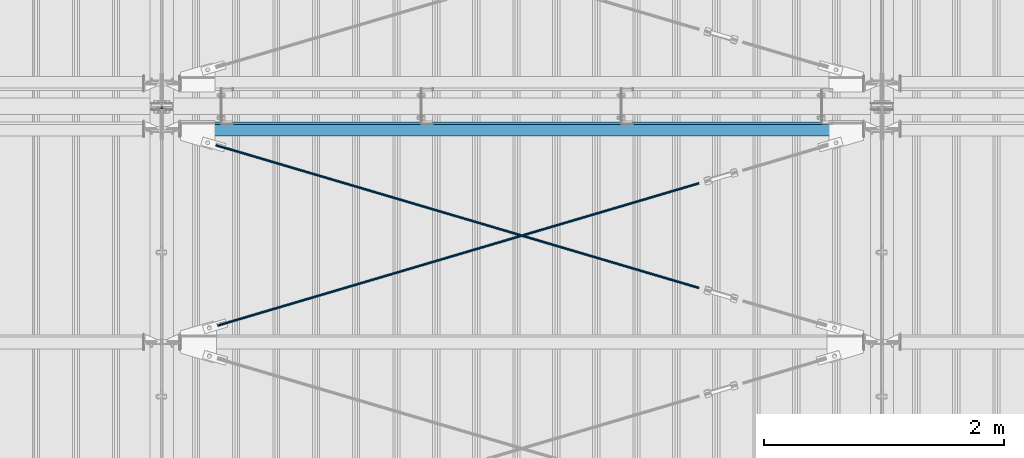
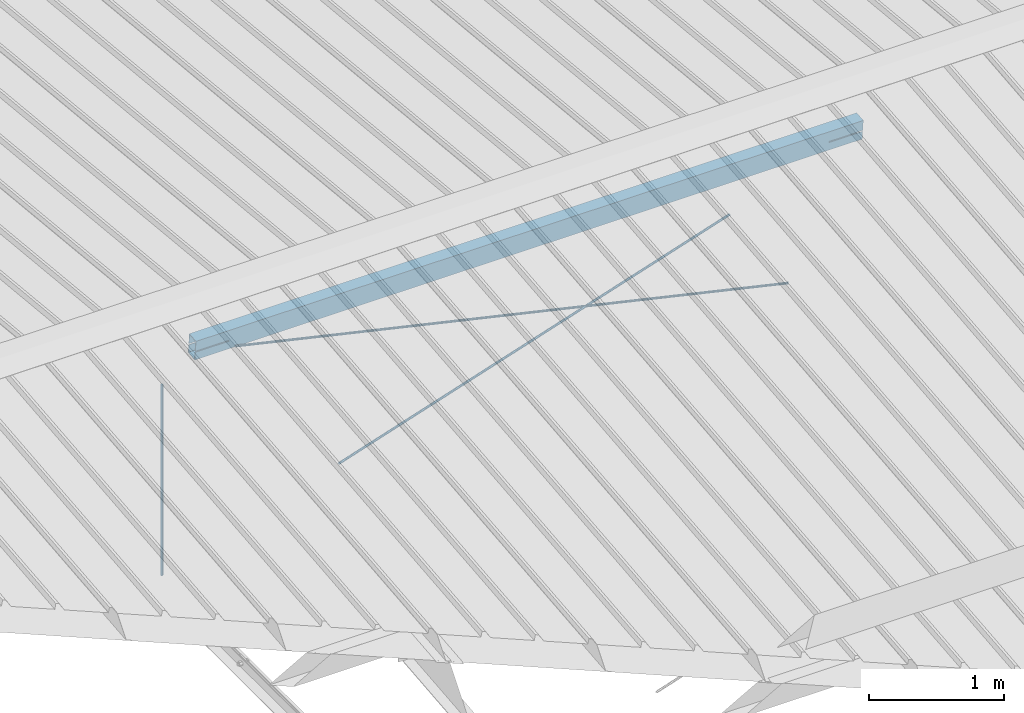
# One storey, part 246 of 709: 4 beams, 4 openings, 4 elements without a shape of their own.
"""IFC4 building model written with IfcOpenShell, lengths in millimetres."""

from ifc_helpers import new_model, si_unit, direction, frame, origin_with_axes, place, context, subcontext, project, spatial, line, indexed_curve, outline, extrude, polygons, material, element, aggregate, save


model = new_model("IFC4")

# Units and contexts
model_context = context("Model", 3, precision=0.2, world=origin_with_axes(), true_north=direction((0.0, 1.0)))
body_context = subcontext(model_context, "Body", "Model", "MODEL_VIEW")
reference_context = subcontext(model_context, "Reference", "Model", "MODEL_VIEW")
ifc_project = project(units=[si_unit("LENGTHUNIT", "METRE", prefix="MILLI"), si_unit("AREAUNIT", "SQUARE_METRE"), si_unit("VOLUMEUNIT", "CUBIC_METRE"), si_unit("MASSUNIT", "GRAM", prefix="KILO"), si_unit("TIMEUNIT", "SECOND"), si_unit("PLANEANGLEUNIT", "RADIAN"), si_unit("SOLIDANGLEUNIT", "STERADIAN"), si_unit("THERMODYNAMICTEMPERATUREUNIT", "DEGREE_CELSIUS"), si_unit("LUMINOUSINTENSITYUNIT", "LUMEN")], contexts=[model_context])

# Site, building, storey
site_placement = place(None, origin_with_axes())
site = spatial("IfcSite", under=ifc_project, at=site_placement, CompositionType="ELEMENT")
building_placement = place(site_placement, origin_with_axes())
building = spatial("IfcBuilding", under=site, at=building_placement, Name="Undefined", CompositionType="ELEMENT")
storey_placement = place(building_placement, origin_with_axes())
storey = spatial("IfcBuildingStorey", under=building, at=storey_placement, Name="Undefined", CompositionType="ELEMENT", Elevation=0.0)

# Assembly, beam
assembly_1_placement = place(storey_placement, frame((4000.0, 10985.0, 8155.10002), z_axis=(0.0, -1.0, 0.0), x_axis=(0.0, 0.0, -1.0)))
assembly_1 = element("IfcElementAssembly", 1, at=assembly_1_placement, inside=storey)
ifc_material_1 = material(Name="C355-5", Category="STEEL")
beam_1_placement = place(assembly_1_placement, origin_with_axes())
beam_1 = element("IfcBeam", 2, at=beam_1_placement, material=ifc_material_1, ObjectType="437", context=body_context, shape_type="Tessellation", body=[
    polygons([(326.36285, 0.0, 10.0), (326.36285, -2.58819, 9.65926), (2045.1, -2.58819, 9.65926), (2045.1, 0.0, 10.0), (326.36285, -5.0, 8.66025), (2045.1, -5.0, 8.66025), (326.36285, -7.07107, 7.07107), (2045.1, -7.07107, 7.07107), (326.36285, -8.66025, 5.0), (2045.1, -8.66025, 5.0), (326.36285, -9.65926, 2.58819), (2045.1, -9.65926, 2.58819), (326.36285, -10.0, 0.0), (2045.1, -10.0, 0.0), (326.36285, -9.65926, -2.58819), (2045.1, -9.65926, -2.58819), (326.36285, -8.66025, -5.0), (2045.1, -8.66025, -5.0), (326.36285, -7.07107, -7.07107), (2045.1, -7.07107, -7.07107), (326.36285, -5.0, -8.66025), (2045.1, -5.0, -8.66025), (326.36285, -2.58819, -9.65926), (2045.1, -2.58819, -9.65926), (326.36285, 0.0, -10.0), (2045.1, 0.0, -10.0), (326.36285, 2.58819, -9.65926), (2045.1, 2.58819, -9.65926), (326.36285, 5.0, -8.66025), (2045.1, 5.0, -8.66025), (326.36285, 7.07107, -7.07107), (2045.1, 7.07107, -7.07107), (326.36285, 8.66025, -5.0), (2045.1, 8.66025, -5.0), (326.36285, 9.65926, -2.58819), (2045.1, 9.65926, -2.58819), (326.36285, 10.0, 0.0), (2045.1, 10.0, 0.0), (326.36285, 9.65926, 2.58819), (2045.1, 9.65926, 2.58819), (326.36285, 8.66025, 5.0), (2045.1, 8.66025, 5.0), (326.36285, 7.07107, 7.07107), (2045.1, 7.07107, 7.07107), (326.36285, 5.0, 8.66025), (2045.1, 5.0, 8.66025), (326.36285, 2.58819, 9.65926), (2045.1, 2.58819, 9.65926)], [[[1, 2, 3, 4]], [[2, 5, 6, 3]], [[5, 7, 8, 6]], [[7, 9, 10, 8]], [[9, 11, 12, 10]], [[11, 13, 14, 12]], [[13, 15, 16, 14]], [[15, 17, 18, 16]], [[17, 19, 20, 18]], [[19, 21, 22, 20]], [[21, 23, 24, 22]], [[23, 25, 26, 24]], [[25, 27, 28, 26]], [[27, 29, 30, 28]], [[29, 31, 32, 30]], [[31, 33, 34, 32]], [[33, 35, 36, 34]], [[35, 37, 38, 36]], [[37, 39, 40, 38]], [[39, 41, 42, 40]], [[41, 43, 44, 42]], [[43, 45, 46, 44]], [[45, 47, 48, 46]], [[47, 1, 4, 48]], [[6, 8, 10, 12, 14, 16, 18, 20, 22, 24, 26, 28, 30, 32, 34, 36, 38, 40, 42, 44, 46, 48, 4, 3]], [[47, 45, 43, 41, 39, 37, 35, 33, 31, 29, 27, 25, 23, 21, 19, 17, 15, 13, 11, 9, 7, 5, 2, 1]]], closed=True),
])
aggregate(assembly_1, [beam_1])

# Assembly, beam, voiding feature
assembly_2_placement = place(storey_placement, frame((4000.0, 9035.85409, 8040.08943), z_axis=(0.2847296511, -0.9538504697, -0.095385047), x_axis=(0.9586078582, 0.2833165921, 0.028331659)))
assembly_2 = element("IfcElementAssembly", 3, at=assembly_2_placement, inside=storey)
beam_2_placement = place(assembly_2_placement, origin_with_axes())
beam_2 = element("IfcBeam", 4, at=beam_2_placement, material=ifc_material_1, ObjectType="572", context=body_context, shape_type="Tessellation", body=[
    polygons([(4849.07659, 7.36122, 4.25), (4849.07659, 6.01041, 6.01041), (4849.07659, 4.25, 7.36122), (4849.07659, 2.19996, 8.21037), (4849.07659, 0.0, 8.5), (4849.07659, -2.19996, 8.21037), (4849.07659, -4.25, 7.36122), (4849.07659, -6.01041, 6.01041), (4849.07659, -7.36121, 4.25), (4849.07659, -8.21037, 2.19996), (4849.07659, -8.5, 0.0), (4849.07659, -8.21037, -2.19996), (4849.07659, -7.36121, -4.25), (4849.07659, -6.01041, -6.01041), (4849.07659, -4.25, -7.36122), (4849.07659, -2.19996, -8.21037), (4849.07659, 0.0, -8.5), (4849.07659, 2.19996, -8.21037), (4849.07659, 4.25, -7.36122), (4849.07659, 6.01041, -6.01041), (4849.07659, 7.36122, -4.25), (4849.07659, 8.21037, -2.19996), (4849.07659, 8.5, 0.0), (4849.07659, 8.21037, 2.19996), (4669.07659, 8.21037, 2.19996), (4669.07659, 7.36122, 4.25), (4669.07659, 6.01041, 6.01041), (4669.07659, 4.25, 7.36122), (4669.07659, 2.19996, 8.21037), (4669.07659, 0.0, 8.5), (4669.07659, -2.19996, 8.21037), (4669.07659, -4.25, 7.36122), (4669.07659, -6.01041, 6.01041), (4669.07659, -7.36121, 4.25), (4669.07659, -8.21037, 2.19996), (4669.07659, -8.5, 0.0), (4669.07659, -8.21037, -2.19996), (4669.07659, -7.36121, -4.25), (4669.07659, -6.01041, -6.01041), (4669.07659, -4.25, -7.36122), (4669.07659, -2.19996, -8.21037), (4669.07659, 0.0, -8.5), (4669.07659, 2.19996, -8.21037), (4669.07659, 4.25, -7.36122), (4669.07659, 6.01041, -6.01041), (4669.07659, 7.36122, -4.25), (4669.07659, 8.21037, -2.19996), (4669.07659, 8.5, 0.0), (4669.07659, 10.0, 0.0), (4669.07659, 9.65926, 2.58819), (4669.07659, 8.66025, 5.0), (4669.07659, 7.07107, 7.07107), (4669.07659, 5.0, 8.66025), (4669.07659, 2.58819, 9.65926), (4669.07659, 0.0, 10.0), (4669.07659, -2.58819, 9.65926), (4669.07659, -5.0, 8.66025), (4669.07659, -7.07107, 7.07107), (4669.07659, -8.66025, 5.0), (4669.07659, -9.65926, 2.58819), (4669.07659, -10.0, 0.0), (4669.07659, -9.65926, -2.58819), (4669.07659, -8.66025, -5.0), (4669.07659, -7.07107, -7.07107), (4669.07659, -5.0, -8.66025), (4669.07659, -2.58819, -9.65926), (4669.07659, 0.0, -10.0), (4669.07659, 2.58819, -9.65926), (4669.07659, 5.0, -8.66025), (4669.07659, 7.07107, -7.07107), (4669.07659, 8.66025, -5.0), (4669.07659, 9.65926, -2.58819), (483.68279, 2.58819, 9.65926), (483.68279, 5.0, 8.66025), (483.68279, 7.07107, 7.07107), (483.68279, 8.66025, 5.0), (483.68279, 9.65926, 2.58819), (483.68279, 10.0, 0.0), (483.68279, 9.65926, -2.58819), (483.68279, 8.66025, -5.0), (483.68279, 7.07107, -7.07107), (483.68279, 5.0, -8.66025), (483.68279, 2.58819, -9.65926), (483.68279, 0.0, -10.0), (483.68279, -2.58819, -9.65926), (483.68279, -5.0, -8.66025), (483.68279, -7.07107, -7.07107), (483.68279, -8.66025, -5.0), (483.68279, -9.65926, -2.58819), (483.68279, -10.0, 0.0), (483.68279, -9.65926, 2.58819), (483.68279, -8.66025, 5.0), (483.68279, -7.07107, 7.07107), (483.68279, -5.0, 8.66025), (483.68279, -2.58819, 9.65926), (483.68279, 0.0, 10.0)], [[[1, 2, 3, 4, 5, 6, 7, 8, 9, 10, 11, 12, 13, 14, 15, 16, 17, 18, 19, 20, 21, 22, 23, 24]], [[24, 25, 26, 1]], [[1, 26, 27, 2]], [[2, 27, 28, 3]], [[3, 28, 29, 4]], [[4, 29, 30, 5]], [[5, 30, 31, 6]], [[6, 31, 32, 7]], [[7, 32, 33, 8]], [[8, 33, 34, 9]], [[9, 34, 35, 10]], [[10, 35, 36, 11]], [[11, 36, 37, 12]], [[12, 37, 38, 13]], [[13, 38, 39, 14]], [[14, 39, 40, 15]], [[15, 40, 41, 16]], [[16, 41, 42, 17]], [[17, 42, 43, 18]], [[18, 43, 44, 19]], [[19, 44, 45, 20]], [[20, 45, 46, 21]], [[21, 46, 47, 22]], [[22, 47, 48, 23]], [[23, 48, 25, 24]], [[49, 50, 51, 52, 53, 54, 55, 56, 57, 58, 59, 60, 61, 62, 63, 64, 65, 66, 67, 68, 69, 70, 71, 72], [47, 46, 45, 44, 43, 42, 41, 40, 39, 38, 37, 36, 35, 34, 33, 32, 31, 30, 29, 28, 27, 26, 25, 48]], [[73, 74, 75, 76, 77, 78, 79, 80, 81, 82, 83, 84, 85, 86, 87, 88, 89, 90, 91, 92, 93, 94, 95, 96]], [[79, 78, 49, 72]], [[80, 79, 72, 71]], [[81, 80, 71, 70]], [[82, 81, 70, 69]], [[83, 82, 69, 68]], [[84, 83, 68, 67]], [[85, 84, 67, 66]], [[86, 85, 66, 65]], [[87, 86, 65, 64]], [[88, 87, 64, 63]], [[89, 88, 63, 62]], [[90, 89, 62, 61]], [[91, 90, 61, 60]], [[92, 91, 60, 59]], [[93, 92, 59, 58]], [[94, 93, 58, 57]], [[95, 94, 57, 56]], [[96, 95, 56, 55]], [[73, 96, 55, 54]], [[74, 73, 54, 53]], [[75, 74, 53, 52]], [[76, 75, 52, 51]], [[77, 76, 51, 50]], [[78, 77, 50, 49]]], closed=True),
])
voiding_feature_1_placement = place(beam_2_placement, frame((4849.07659, 0.0, 0.0), z_axis=(0.0, 1.0, 0.0), x_axis=(-1.0, 0.0, 0.0)))
element("IfcVoidingFeature", 5, at=voiding_feature_1_placement, cuts=beam_2, PredefinedType="HOLE", context=reference_context, identifier="Reference", shape_type="SolidModel", body=[
    extrude(outline(indexed_curve([(10.5, 0.0), (10.14222, 2.7176), (9.09327, 5.25), (7.42462, 7.42462), (5.25, 9.09327), (2.7176, 10.14222), (0.0, 10.5), (-2.7176, 10.14222), (-5.25, 9.09327), (-7.42462, 7.42462), (-9.09327, 5.25), (-10.14222, 2.7176), (-10.5, 0.0), (-10.14222, -2.7176), (-9.09327, -5.25), (-7.42462, -7.42462), (-5.25, -9.09327), (-2.7176, -10.14222), (0.0, -10.5), (2.7176, -10.14222), (5.25, -9.09327), (7.42462, -7.42462), (9.09327, -5.25), (10.14222, -2.7176)], segments=[line(1, 2, 3, 4, 5, 6, 7, 8, 9, 10, 11, 12, 13, 14, 15, 16, 17, 18, 19, 20, 21, 22, 23, 24, 1)])), frame((0.0, 0.0, 0.0), z_axis=(-1.0, 0.0, 0.0), x_axis=(0.0, 0.0, 1.0)), (0.0, 0.0, -1.0), 180.0),
])
aggregate(assembly_2, [beam_2])

assembly_3_placement = place(storey_placement, frame((4000.0, 10809.15434, 8217.41945), z_axis=(-0.2847296511, -0.9538504697, -0.095385047), x_axis=(0.9586078582, -0.2833165921, -0.028331659)))
assembly_3 = element("IfcElementAssembly", 6, at=assembly_3_placement, inside=storey)
beam_3_placement = place(assembly_3_placement, origin_with_axes())
beam_3 = element("IfcBeam", 7, at=beam_3_placement, material=ifc_material_1, ObjectType="573", context=body_context, shape_type="Tessellation", body=[
    polygons([(4849.07659, 7.36121, 4.25), (4849.07659, 6.01041, 6.01041), (4849.07659, 4.25, 7.36122), (4849.07659, 2.19996, 8.21037), (4849.07659, 0.0, 8.5), (4849.07659, -2.19996, 8.21037), (4849.07659, -4.25, 7.36122), (4849.07659, -6.01041, 6.01041), (4849.07659, -7.36122, 4.25), (4849.07659, -8.21037, 2.19996), (4849.07659, -8.5, 0.0), (4849.07659, -8.21037, -2.19996), (4849.07659, -7.36122, -4.25), (4849.07659, -6.01041, -6.01041), (4849.07659, -4.25, -7.36122), (4849.07659, -2.19996, -8.21037), (4849.07659, 0.0, -8.5), (4849.07659, 2.19996, -8.21037), (4849.07659, 4.25, -7.36122), (4849.07659, 6.01041, -6.01041), (4849.07659, 7.36121, -4.25), (4849.07659, 8.21037, -2.19996), (4849.07659, 8.5, 0.0), (4849.07659, 8.21037, 2.19996), (4669.07659, 8.21037, 2.19996), (4669.07659, 7.36121, 4.25), (4669.07659, 6.01041, 6.01041), (4669.07659, 4.25, 7.36122), (4669.07659, 2.19996, 8.21037), (4669.07659, 0.0, 8.5), (4669.07659, -2.19996, 8.21037), (4669.07659, -4.25, 7.36122), (4669.07659, -6.01041, 6.01041), (4669.07659, -7.36122, 4.25), (4669.07659, -8.21037, 2.19996), (4669.07659, -8.5, 0.0), (4669.07659, -8.21037, -2.19996), (4669.07659, -7.36122, -4.25), (4669.07659, -6.01041, -6.01041), (4669.07659, -4.25, -7.36122), (4669.07659, -2.19996, -8.21037), (4669.07659, 0.0, -8.5), (4669.07659, 2.19996, -8.21037), (4669.07659, 4.25, -7.36122), (4669.07659, 6.01041, -6.01041), (4669.07659, 7.36121, -4.25), (4669.07659, 8.21037, -2.19996), (4669.07659, 8.5, 0.0), (4669.07659, 10.0, 0.0), (4669.07659, 9.65926, 2.58819), (4669.07659, 8.66025, 5.0), (4669.07659, 7.07107, 7.07107), (4669.07659, 5.0, 8.66025), (4669.07659, 2.58819, 9.65926), (4669.07659, 0.0, 10.0), (4669.07659, -2.58819, 9.65926), (4669.07659, -5.0, 8.66025), (4669.07659, -7.07107, 7.07107), (4669.07659, -8.66025, 5.0), (4669.07659, -9.65926, 2.58819), (4669.07659, -10.0, 0.0), (4669.07659, -9.65926, -2.58819), (4669.07659, -8.66025, -5.0), (4669.07659, -7.07107, -7.07107), (4669.07659, -5.0, -8.66025), (4669.07659, -2.58819, -9.65926), (4669.07659, 0.0, -10.0), (4669.07659, 2.58819, -9.65926), (4669.07659, 5.0, -8.66025), (4669.07659, 7.07107, -7.07107), (4669.07659, 8.66025, -5.0), (4669.07659, 9.65926, -2.58819), (468.68279, 2.58819, 9.65926), (468.68279, 5.0, 8.66025), (468.68279, 7.07107, 7.07107), (468.68279, 8.66025, 5.0), (468.68279, 9.65926, 2.58819), (468.68279, 10.0, 0.0), (468.68279, 9.65926, -2.58819), (468.68279, 8.66025, -5.0), (468.68279, 7.07107, -7.07107), (468.68279, 5.0, -8.66025), (468.68279, 2.58819, -9.65926), (468.68279, 0.0, -10.0), (468.68279, -2.58819, -9.65926), (468.68279, -5.0, -8.66025), (468.68279, -7.07107, -7.07107), (468.68279, -8.66025, -5.0), (468.68279, -9.65926, -2.58819), (468.68279, -10.0, 0.0), (468.68279, -9.65926, 2.58819), (468.68279, -8.66025, 5.0), (468.68279, -7.07107, 7.07107), (468.68279, -5.0, 8.66025), (468.68279, -2.58819, 9.65926), (468.68279, 0.0, 10.0)], [[[1, 2, 3, 4, 5, 6, 7, 8, 9, 10, 11, 12, 13, 14, 15, 16, 17, 18, 19, 20, 21, 22, 23, 24]], [[24, 25, 26, 1]], [[1, 26, 27, 2]], [[2, 27, 28, 3]], [[3, 28, 29, 4]], [[4, 29, 30, 5]], [[5, 30, 31, 6]], [[6, 31, 32, 7]], [[7, 32, 33, 8]], [[8, 33, 34, 9]], [[9, 34, 35, 10]], [[10, 35, 36, 11]], [[11, 36, 37, 12]], [[12, 37, 38, 13]], [[13, 38, 39, 14]], [[14, 39, 40, 15]], [[15, 40, 41, 16]], [[16, 41, 42, 17]], [[17, 42, 43, 18]], [[18, 43, 44, 19]], [[19, 44, 45, 20]], [[20, 45, 46, 21]], [[21, 46, 47, 22]], [[22, 47, 48, 23]], [[23, 48, 25, 24]], [[49, 50, 51, 52, 53, 54, 55, 56, 57, 58, 59, 60, 61, 62, 63, 64, 65, 66, 67, 68, 69, 70, 71, 72], [47, 46, 45, 44, 43, 42, 41, 40, 39, 38, 37, 36, 35, 34, 33, 32, 31, 30, 29, 28, 27, 26, 25, 48]], [[73, 74, 75, 76, 77, 78, 79, 80, 81, 82, 83, 84, 85, 86, 87, 88, 89, 90, 91, 92, 93, 94, 95, 96]], [[79, 78, 49, 72]], [[80, 79, 72, 71]], [[81, 80, 71, 70]], [[82, 81, 70, 69]], [[83, 82, 69, 68]], [[84, 83, 68, 67]], [[85, 84, 67, 66]], [[86, 85, 66, 65]], [[87, 86, 65, 64]], [[88, 87, 64, 63]], [[89, 88, 63, 62]], [[90, 89, 62, 61]], [[91, 90, 61, 60]], [[92, 91, 60, 59]], [[93, 92, 59, 58]], [[94, 93, 58, 57]], [[95, 94, 57, 56]], [[96, 95, 56, 55]], [[73, 96, 55, 54]], [[74, 73, 54, 53]], [[75, 74, 53, 52]], [[76, 75, 52, 51]], [[77, 76, 51, 50]], [[78, 77, 50, 49]]], closed=True),
])
voiding_feature_2_placement = place(beam_3_placement, frame((4849.07659, 0.0, 0.0), z_axis=(0.0, 1.0, 0.0), x_axis=(-1.0, 0.0, 0.0)))
element("IfcVoidingFeature", 8, at=voiding_feature_2_placement, cuts=beam_3, PredefinedType="HOLE", context=reference_context, identifier="Reference", shape_type="SolidModel", body=[
    extrude(outline(indexed_curve([(10.5, 0.0), (10.14222, 2.7176), (9.09327, 5.25), (7.42462, 7.42462), (5.25, 9.09327), (2.7176, 10.14222), (0.0, 10.5), (-2.7176, 10.14222), (-5.25, 9.09327), (-7.42462, 7.42462), (-9.09327, 5.25), (-10.14222, 2.7176), (-10.5, 0.0), (-10.14222, -2.7176), (-9.09327, -5.25), (-7.42462, -7.42462), (-5.25, -9.09327), (-2.7176, -10.14222), (0.0, -10.5), (2.7176, -10.14222), (5.25, -9.09327), (7.42462, -7.42462), (9.09327, -5.25), (10.14222, -2.7176)], segments=[line(1, 2, 3, 4, 5, 6, 7, 8, 9, 10, 11, 12, 13, 14, 15, 16, 17, 18, 19, 20, 21, 22, 23, 24, 1)])), frame((0.0, 0.0, 0.0), z_axis=(-1.0, 0.0, 0.0), x_axis=(0.0, 0.0, 1.0)), (0.0, 0.0, -1.0), 180.0),
])
aggregate(assembly_3, [beam_3])

# Assembly, beam, voiding features
assembly_4_placement = place(storey_placement, frame((4000.0, 10808.95533, 8219.40952), z_axis=(0.0, 0.9950371902, 0.099503719), x_axis=(1.0, 0.0, 0.0)))
assembly_4 = element("IfcElementAssembly", 9, at=assembly_4_placement, inside=storey)
ifc_material_2 = material(Name="C355", Category="STEEL")
beam_4_placement = place(assembly_4_placement, origin_with_axes())
beam_4 = element("IfcBeam", 10, at=beam_4_placement, material=ifc_material_2, ObjectType="567", context=body_context, shape_type="Tessellation", body=[
    polygons([(442.92369, 5.0, 50.0), (442.92369, 5.0, 46.0), (155.0, 5.0, 46.0), (155.0, 5.0, 50.0), (442.92369, 15.0, 50.0), (442.92369, 15.0, 46.0), (155.0, 15.0, 50.0), (155.0, 15.0, 46.0), (442.92369, 5.0, -46.0), (442.92369, 5.0, -50.0), (155.0, 5.0, -50.0), (155.0, 5.0, -46.0), (442.92369, 15.0, -46.0), (442.92369, 15.0, -50.0), (155.0, 15.0, -46.0), (155.0, 15.0, -50.0), (155.0, 86.0, 46.0), (155.0, 86.0, -46.0), (5845.0, 86.0, -46.0), (5845.0, 86.0, 46.0), (155.0, 90.0, -50.0), (5845.0, 90.0, -50.0), (5845.0, 15.0, -50.0), (5557.07631, 15.0, -50.0), (5557.07631, 5.0, -50.0), (5845.0, 5.0, -50.0), (5845.0, -90.0, -50.0), (155.0, -90.0, -50.0), (5845.0, 15.0, -46.0), (5557.07631, 15.0, -46.0), (5557.07631, 5.0, -46.0), (5845.0, 5.0, -46.0), (155.0, -86.0, -46.0), (155.0, -86.0, 46.0), (5845.0, -86.0, 46.0), (5845.0, -86.0, -46.0), (5557.07631, 5.0, 50.0), (5557.07631, 5.0, 46.0), (5557.07631, 15.0, 46.0), (5557.07631, 15.0, 50.0), (5845.0, 5.0, 50.0), (5845.0, 5.0, 46.0), (5845.0, -90.0, 50.0), (155.0, -90.0, 50.0), (5845.0, 15.0, 46.0), (5845.0, 15.0, 50.0), (5845.0, 90.0, 50.0), (155.0, 90.0, 50.0)], [[[1, 2, 3, 4]], [[5, 6, 2, 1]], [[7, 8, 6, 5]], [[9, 10, 11, 12]], [[13, 14, 10, 9]], [[15, 16, 14, 13]], [[17, 18, 19, 20]], [[21, 22, 23, 24, 25, 26, 27, 28, 11, 10, 14, 16]], [[29, 30, 24, 23]], [[31, 25, 24, 30]], [[32, 26, 25, 31]], [[33, 34, 35, 36]], [[37, 38, 39, 40]], [[41, 42, 38, 37]], [[43, 27, 26, 32, 36, 35, 42, 41]], [[44, 28, 27, 43]], [[34, 33, 12, 11, 28, 44, 4, 3]], [[17, 20, 45, 39, 38, 42, 35, 34, 3, 2, 6, 8]], [[46, 40, 39, 45]], [[20, 19, 29, 23, 22, 47, 46, 45]], [[21, 48, 47, 22]], [[4, 44, 43, 41, 37, 40, 46, 47, 48, 7, 5, 1]], [[48, 21, 16, 15, 18, 17, 8, 7]], [[12, 33, 36, 32, 31, 30, 29, 19, 18, 15, 13, 9]]], closed=True),
])
voiding_feature_3_placement = place(beam_4_placement, frame((5845.0, 10.0, 70.0), z_axis=(0.0, -1.0, 0.0), x_axis=(-1.0, 0.0, 0.0)))
element("IfcVoidingFeature", 11, at=voiding_feature_3_placement, cuts=beam_4, PredefinedType="HOLE", context=reference_context, identifier="Reference", shape_type="SolidModel", body=[
    extrude(outline(indexed_curve([(0.0, 0.0), (287.92369, 0.0), (287.92369, 154.61594), (262.29802, 240.89065), (0.0, 162.98181)], segments=[line(1, 2, 3, 4, 5, 1)])), frame((0.0, 0.0, 5.0), z_axis=(0.0, 0.0, 1.0), x_axis=(1.0, 0.0, 0.0)), (0.0, 0.0, -1.0), 10.0),
])
voiding_feature_4_placement = place(beam_4_placement, frame((442.92369, 10.0, 70.0), z_axis=(0.0, -1.0, 0.0), x_axis=(-1.0, 0.0, 0.0)))
element("IfcVoidingFeature", 12, at=voiding_feature_4_placement, cuts=beam_4, PredefinedType="HOLE", context=reference_context, identifier="Reference", shape_type="SolidModel", body=[
    extrude(outline(indexed_curve([(0.0, 0.0), (287.92369, 0.0), (287.92369, 162.98181), (25.62567, 240.89065), (0.0, 154.61594)], segments=[line(1, 2, 3, 4, 5, 1)])), frame((0.0, 0.0, 5.0), z_axis=(0.0, 0.0, 1.0), x_axis=(1.0, 0.0, 0.0)), (0.0, 0.0, -1.0), 10.0),
])
aggregate(assembly_4, [beam_4])

save(model, "model.ifc")
